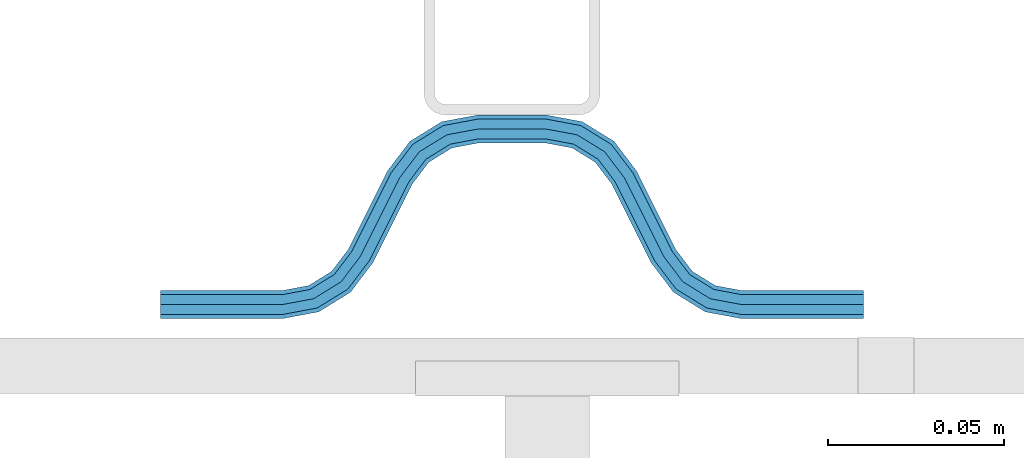
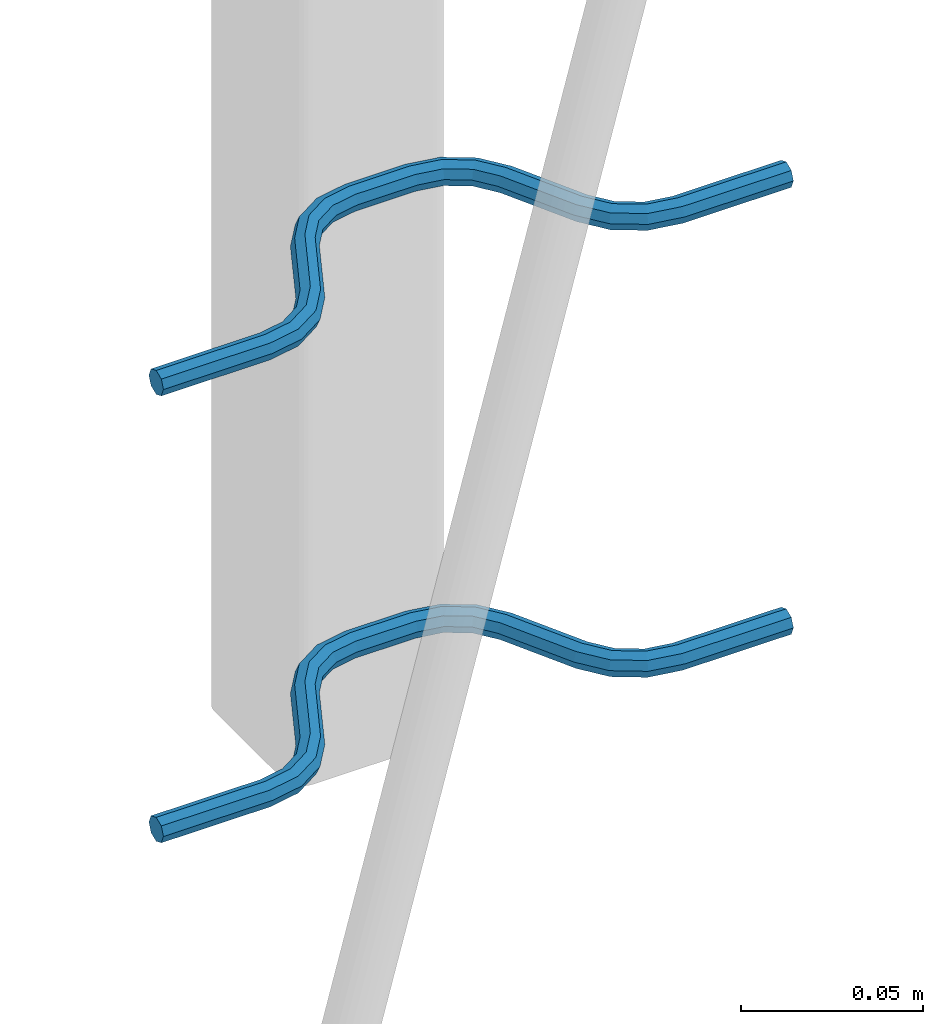
# One storey, part 4 of 5: 2 beams, 2 elements without a shape of their own.
"""IFC2X3 building model written with IfcOpenShell, lengths in millimetres."""

from ifc_helpers import new_model, si_unit, frame, origin_with_axes, place, context, subcontext, project, spatial, faceted_brep, material, type_object, element, aggregate, save


model = new_model("IFC2X3")

# Units and contexts
model_context = context("Model", 3, precision=1e-05, world=origin_with_axes())
body_context = subcontext(model_context, "Body", "Model", "MODEL_VIEW")
ifc_project = project(units=[si_unit("LENGTHUNIT", "METRE", prefix="MILLI"), si_unit("AREAUNIT", "SQUARE_METRE"), si_unit("VOLUMEUNIT", "CUBIC_METRE"), si_unit("MASSUNIT", "GRAM", prefix="KILO"), si_unit("TIMEUNIT", "SECOND"), si_unit("PLANEANGLEUNIT", "RADIAN"), si_unit("SOLIDANGLEUNIT", "STERADIAN"), si_unit("THERMODYNAMICTEMPERATUREUNIT", "DEGREE_CELSIUS"), si_unit("LUMINOUSINTENSITYUNIT", "LUMEN")], contexts=[model_context])

# Site, building, storey
site_placement = place(None, origin_with_axes())
site = spatial("IfcSite", under=ifc_project, at=site_placement, CompositionType="ELEMENT")
building_placement = place(site_placement, origin_with_axes())
building = spatial("IfcBuilding", under=site, at=building_placement, Name="Undefined", CompositionType="ELEMENT")
storey_placement = place(building_placement, origin_with_axes())
storey = spatial("IfcBuildingStorey", under=building, at=storey_placement, Name="Undefined", CompositionType="ELEMENT", Elevation=0.0)

# Assembly, beam
assembly_1_placement = place(storey_placement, origin_with_axes())
assembly_1 = element("IfcElementAssembly", 1, at=assembly_1_placement, inside=storey, Name="Steel Assembly", AssemblyPlace="NOTDEFINED", PredefinedType="NOTDEFINED")
ifc_material = material(Name="REBAR/A500HW")
beam_type = type_object("IfcBeamType", Name="D8", PredefinedType="NOTDEFINED")
beam_1_placement = place(assembly_1_placement, frame((42320.0028955972, 6595.97468822386, 2580.99992151562), z_axis=(0.0, 0.0, 1.0), x_axis=(-0.999999999544916, 3.01690000137701e-05, 0.0)))
beam_1 = element("IfcBeam", 2, at=beam_1_placement, type_object=beam_type, material=ifc_material, Name="AnchorRebar", ObjectType="D8", context=body_context, shape_type="Brep", body=[
    faceted_brep([(3.97994881495833e-09, -4.00000000000091, 0.0), (2.8085196390748e-09, -2.82842712474758, -2.82842712474621), (34.5491497841067, -2.82842709033048, -2.82842712474621), (34.5491497849507, -3.99999996579936, 0.0), (-7.27595761418343e-12, -9.09494701772928e-13, -4.0), (34.5491497812909, 3.44161890097894e-08, -4.0), (-2.82307155430317e-09, 2.82842712474485, -2.82842712474621), (34.5491497784751, 2.82842715916104, -2.82842712474621), (-3.9945007301867e-09, 3.99999999999909, 0.0), (34.5491497773037, 4.00000003441619, 0.0), (-2.82307155430317e-09, 2.82842712474485, 2.82842712474621), (34.5491497784751, 2.82842715916104, 2.82842712474621), (-7.27595761418343e-12, -9.09494701772928e-13, 4.0), (34.5491497812909, 3.44161890097894e-08, 4.0), (2.8085196390748e-09, -2.82842712474758, 2.82842712474621), (34.5491497841067, -2.82842709033048, 2.82842712474621), (45.0102956714691, 2.04744773578568, 0.0), (44.5876751631804, 0.954756147099033, -2.82842712474621), (43.5673790003711, -1.68323470581527, -4.0), (42.5470828375619, -4.3212255587232, -2.82842712474621), (42.1244623293023, -5.41391714741258, 0.0), (42.5470828375619, -4.3212255587232, 2.82842712474621), (43.5673790003711, -1.68323470581527, 4.0), (44.5876751631804, 0.954756147099033, 2.82842712474621), (53.274424971547, -4.41395065588222, 2.82842712474621), (54.0627564272581, -3.5472808699069, 0.0), (51.3712244794879, -6.50627660728151, 4.0), (49.4680239874506, -8.59860255868261, 2.82842712474621), (48.6796925317176, -9.4652723446543, 0.0), (49.4680239874506, -8.59860255868261, -2.82842712474621), (51.3712244794879, -6.50627660728151, -4.0), (53.274424971547, -4.41395065588222, -2.82842712474621), (59.4396520724549, -12.5547497421876, 2.82842712474621), (60.4875387236025, -12.0308064548954, 0.0), (56.9098299073739, -13.8196607322834, 4.0), (54.3800077422784, -15.0845717223683, 2.82842712474621), (53.3321210918803, -15.6085150094559, 0.0), (54.3800077422784, -15.0845717223683, -2.82842712474621), (56.9098299073739, -13.8196607322834, -4.0), (59.4396520724549, -12.5547497421876, -2.82842712474621), (65.5603461982682, -37.4452502676068, -2.82842712474621), (64.5124595463058, -37.9691935549445, 0.0), (68.0901683634002, -36.1803392775319, -4.0), (70.6199905285321, -34.9154282874579, -2.82842712474621), (71.6678771797233, -34.3914850001738, 0.0), (70.6199905285321, -34.9154282874579, 2.82842712474621), (68.0901683634002, -36.1803392775319, 4.0), (65.5603461982682, -37.4452502676068, 2.82842712474621), (76.3203055137128, -40.5347274610476, 0.0), (75.5319740454433, -41.4013972356079, -2.82842712474621), (73.628773523058, -43.4937231594477, -4.0), (71.7255730006873, -45.586049083292, -2.82842712474621), (70.9372415324033, -46.4527188578513, 0.0), (71.7255730006873, -45.586049083292, 2.82842712474621), (73.628773523058, -43.4937231594477, 4.0), (75.5319740454433, -41.4013972356079, 2.82842712474621), (82.4529148344736, -45.6787742201832, 2.82842712474621), (82.8755353743836, -44.5860826437265, 0.0), (81.4326185952377, -48.3167650435544, 4.0), (80.4123223560309, -50.9547558669201, 2.82842712474621), (79.9897018161209, -52.0474474433813, 0.0), (80.4123223560309, -50.9547558669201, -2.82842712474621), (81.4326185952377, -48.3167650435544, -4.0), (82.4529148344736, -45.6787742201832, -2.82842712474621), (90.4508475245966, -47.1715729199359, 2.82842712474621), (90.4508475742841, -46.000000044688, 0.0), (90.4508474046088, -50.0000000446771, 4.0), (90.4508472846428, -52.8284271694056, 2.82842712474621), (90.4508472356392, -54.0000000440459, 0.0), (90.4508472846428, -52.8284271694056, -2.82842712474621), (90.4508474046088, -50.0000000446771, -4.0), (90.4508475245966, -47.1715729199359, -2.82842712474621), (109.549147724516, -52.8284279786703, -2.82842712474621), (109.54914767341, -54.0000008540392, 0.0), (109.54914784446, -50.0000008539246, -4.0), (109.549147964404, -47.171573729177, -2.82842712474621), (109.549148014084, -46.0000008539246, 0.0), (109.549147964404, -47.171573729177, 2.82842712474621), (109.54914784446, -50.0000008539246, 4.0), (109.549147724516, -52.8284279786703, 2.82842712474621), (120.010293570755, -52.0474490194165, 0.0), (119.58767311088, -50.954757411987, 2.82842712474621), (118.567377064988, -48.316766513838, 4.0), (117.547081019067, -45.6787756156891, 2.82842712474621), (117.124460559222, -44.586084008266, 0.0), (117.547081019067, -45.6787756156891, -2.82842712474621), (118.567377064988, -48.316766513838, -4.0), (119.58767311088, -50.954757411987, -2.82842712474621), (128.274423097741, -45.5860510482489, -2.82842712474621), (129.062754512561, -46.4527208714499, 0.0), (126.371222704453, -43.4937250069761, -4.0), (124.468022311172, -41.4013989657033, -2.82842712474621), (123.679690896359, -40.5347291425014, 0.0), (124.468022311172, -41.4013989657033, 2.82842712474621), (126.371222704453, -43.4937250069761, 4.0), (128.274423097741, -45.5860510482489, 2.82842712474621), (134.439650547101, -37.4452523250511, -2.82842712474621), (135.487537173387, -37.9691956638335, 0.0), (131.909828445358, -36.1803412081899, -4.0), (129.380006343621, -34.9154300913378, -2.82842712474621), (128.332119718681, -34.3914867515423, 0.0), (129.380006343621, -34.9154300913378, 2.82842712474621), (131.909828445358, -36.1803412081899, 4.0), (134.439650547101, -37.4452523250511, 2.82842712474621), (145.619991993379, -15.0845705988722, -2.82842712474621), (146.66787861682, -15.6085139395227, 0.0), (143.090169891606, -13.8196594820974, -4.0), (140.560347789826, -12.5547483653227, -2.82842712474621), (139.512461164864, -12.0308050255589, 0.0), (140.560347789826, -12.5547483653227, 2.82842712474621), (143.090169891606, -13.8196594820974, 4.0), (145.619991993379, -15.0845705988722, 2.82842712474621), (151.32030721409, -9.46527175248229, 0.0), (150.531975786696, -8.59860194074281, 2.82842712474621), (148.62877536298, -6.50627592714864, 4.0), (146.725574939279, -4.41394991354628, 2.82842712474621), (145.937243511864, -3.5472801018077, 0.0), (146.725574939279, -4.41394991354628, -2.82842712474621), (148.62877536298, -6.50627592714864, -4.0), (150.531975786696, -8.59860194074281, -2.82842712474621), (157.452916717564, -4.32122530571087, -2.82842712474621), (157.875537209118, -5.41391690087676, 0.0), (156.432620595137, -1.68323443716054, -4.0), (155.412324472702, 0.95475643138434, -2.82842712474621), (154.989703981155, 2.04744802655023, 0.0), (155.412324472702, 0.95475643138434, 2.82842712474621), (156.432620595137, -1.68323443716054, 4.0), (157.452916717564, -4.32122530571087, 2.82842712474621), (165.450849409564, -2.82842696003536, -2.82842712474621), (165.450849412795, -3.99999983546877, 0.0), (165.450849406625, 1.64712218975183e-07, -4.0), (165.450849403685, 2.82842728945616, -2.82842712474621), (165.45084940247, 4.00000016471495, 0.0), (165.450849403685, 2.82842728945616, 2.82842712474621), (165.450849406625, 1.64712218975183e-07, 4.0), (165.450849409564, -2.82842696003536, 2.82842712474621), (200.000000091874, -2.82842692587838, -2.82842712474621), (200.000000093038, -3.99999980113171, 0.0), (200.000000089065, 1.98867383005563e-07, -4.0), (200.000000086249, 2.82842732361496, -2.82842712474621), (200.000000085085, 4.00000019886738, 0.0), (200.000000086249, 2.82842732361496, 2.82842712474621), (200.000000089065, 1.98867383005563e-07, 4.0), (200.000000091874, -2.82842692587838, 2.82842712474621)], [[[0, 1, 2, 3]], [[1, 4, 5, 2]], [[4, 6, 7, 5]], [[6, 8, 9, 7]], [[8, 10, 11, 9]], [[10, 12, 13, 11]], [[12, 14, 15, 13]], [[14, 0, 3, 15]], [[14, 12, 10, 8, 6, 4, 1, 0]], [[7, 9, 16, 17]], [[5, 7, 17, 18]], [[2, 5, 18, 19]], [[3, 2, 19, 20]], [[15, 3, 20, 21]], [[13, 15, 21, 22]], [[11, 13, 22, 23]], [[9, 11, 23, 16]], [[23, 24, 25, 16]], [[22, 26, 24, 23]], [[21, 27, 26, 22]], [[20, 28, 27, 21]], [[19, 29, 28, 20]], [[18, 30, 29, 19]], [[17, 31, 30, 18]], [[16, 25, 31, 17]], [[24, 32, 33, 25]], [[26, 34, 32, 24]], [[27, 35, 34, 26]], [[28, 36, 35, 27]], [[29, 37, 36, 28]], [[30, 38, 37, 29]], [[31, 39, 38, 30]], [[25, 33, 39, 31]], [[36, 37, 40, 41]], [[37, 38, 42, 40]], [[38, 39, 43, 42]], [[39, 33, 44, 43]], [[33, 32, 45, 44]], [[32, 34, 46, 45]], [[34, 35, 47, 46]], [[35, 36, 41, 47]], [[43, 44, 48, 49]], [[42, 43, 49, 50]], [[40, 42, 50, 51]], [[41, 40, 51, 52]], [[47, 41, 52, 53]], [[46, 47, 53, 54]], [[45, 46, 54, 55]], [[44, 45, 55, 48]], [[55, 56, 57, 48]], [[54, 58, 56, 55]], [[53, 59, 58, 54]], [[52, 60, 59, 53]], [[51, 61, 60, 52]], [[50, 62, 61, 51]], [[49, 63, 62, 50]], [[48, 57, 63, 49]], [[56, 64, 65, 57]], [[58, 66, 64, 56]], [[59, 67, 66, 58]], [[60, 68, 67, 59]], [[61, 69, 68, 60]], [[62, 70, 69, 61]], [[63, 71, 70, 62]], [[57, 65, 71, 63]], [[68, 69, 72, 73]], [[69, 70, 74, 72]], [[70, 71, 75, 74]], [[71, 65, 76, 75]], [[65, 64, 77, 76]], [[64, 66, 78, 77]], [[66, 67, 79, 78]], [[67, 68, 73, 79]], [[79, 73, 80, 81]], [[78, 79, 81, 82]], [[77, 78, 82, 83]], [[76, 77, 83, 84]], [[75, 76, 84, 85]], [[74, 75, 85, 86]], [[72, 74, 86, 87]], [[73, 72, 87, 80]], [[87, 88, 89, 80]], [[86, 90, 88, 87]], [[85, 91, 90, 86]], [[84, 92, 91, 85]], [[83, 93, 92, 84]], [[82, 94, 93, 83]], [[81, 95, 94, 82]], [[80, 89, 95, 81]], [[88, 96, 97, 89]], [[90, 98, 96, 88]], [[91, 99, 98, 90]], [[92, 100, 99, 91]], [[93, 101, 100, 92]], [[94, 102, 101, 93]], [[95, 103, 102, 94]], [[89, 97, 103, 95]], [[97, 96, 104, 105]], [[96, 98, 106, 104]], [[98, 99, 107, 106]], [[99, 100, 108, 107]], [[100, 101, 109, 108]], [[101, 102, 110, 109]], [[102, 103, 111, 110]], [[103, 97, 105, 111]], [[111, 105, 112, 113]], [[110, 111, 113, 114]], [[109, 110, 114, 115]], [[108, 109, 115, 116]], [[107, 108, 116, 117]], [[106, 107, 117, 118]], [[104, 106, 118, 119]], [[105, 104, 119, 112]], [[119, 120, 121, 112]], [[118, 122, 120, 119]], [[117, 123, 122, 118]], [[116, 124, 123, 117]], [[115, 125, 124, 116]], [[114, 126, 125, 115]], [[113, 127, 126, 114]], [[112, 121, 127, 113]], [[120, 128, 129, 121]], [[122, 130, 128, 120]], [[123, 131, 130, 122]], [[124, 132, 131, 123]], [[125, 133, 132, 124]], [[126, 134, 133, 125]], [[127, 135, 134, 126]], [[121, 129, 135, 127]], [[129, 128, 136, 137]], [[128, 130, 138, 136]], [[130, 131, 139, 138]], [[131, 132, 140, 139]], [[132, 133, 141, 140]], [[133, 134, 142, 141]], [[134, 135, 143, 142]], [[135, 129, 137, 143]], [[138, 139, 140, 141, 142, 143, 137, 136]]]),
])
aggregate(assembly_1, [beam_1])

assembly_2_placement = place(storey_placement, origin_with_axes())
assembly_2 = element("IfcElementAssembly", 3, at=assembly_2_placement, inside=storey, Name="Steel Assembly", AssemblyPlace="NOTDEFINED", PredefinedType="NOTDEFINED")
beam_2_placement = place(assembly_2_placement, frame((42320.0028955972, 6595.97468822386, 2430.99992151562), z_axis=(0.0, 0.0, 1.0), x_axis=(-0.999999999544916, 3.01690000137701e-05, 0.0)))
beam_2 = element("IfcBeam", 4, at=beam_2_placement, type_object=beam_type, material=ifc_material, Name="AnchorRebar", ObjectType="D8", context=body_context, shape_type="Brep", body=[
    faceted_brep([(3.97994881495833e-09, -4.00000000000091, 0.0), (2.8085196390748e-09, -2.82842712474758, -2.82842712474621), (34.5491497841067, -2.82842709033048, -2.82842712474621), (34.5491497849507, -3.99999996579936, 0.0), (-7.27595761418343e-12, -9.09494701772928e-13, -4.0), (34.5491497812909, 3.44161890097894e-08, -4.0), (-2.82307155430317e-09, 2.82842712474485, -2.82842712474621), (34.5491497784751, 2.82842715916104, -2.82842712474621), (-3.9945007301867e-09, 3.99999999999909, 0.0), (34.5491497773037, 4.00000003441619, 0.0), (-2.82307155430317e-09, 2.82842712474485, 2.82842712474621), (34.5491497784751, 2.82842715916104, 2.82842712474621), (-7.27595761418343e-12, -9.09494701772928e-13, 4.0), (34.5491497812909, 3.44161890097894e-08, 4.0), (2.8085196390748e-09, -2.82842712474758, 2.82842712474621), (34.5491497841067, -2.82842709033048, 2.82842712474621), (45.0102956714691, 2.04744773578568, 0.0), (44.5876751631804, 0.954756147099033, -2.82842712474621), (43.5673790003711, -1.68323470581527, -4.0), (42.5470828375619, -4.3212255587232, -2.82842712474621), (42.1244623293023, -5.41391714741258, 0.0), (42.5470828375619, -4.3212255587232, 2.82842712474621), (43.5673790003711, -1.68323470581527, 4.0), (44.5876751631804, 0.954756147099033, 2.82842712474621), (53.274424971547, -4.41395065588222, 2.82842712474621), (54.0627564272581, -3.5472808699069, 0.0), (51.3712244794879, -6.50627660728151, 4.0), (49.4680239874506, -8.59860255868261, 2.82842712474621), (48.6796925317176, -9.4652723446543, 0.0), (49.4680239874506, -8.59860255868261, -2.82842712474621), (51.3712244794879, -6.50627660728151, -4.0), (53.274424971547, -4.41395065588222, -2.82842712474621), (59.4396520724549, -12.5547497421876, 2.82842712474621), (60.4875387236025, -12.0308064548954, 0.0), (56.9098299073739, -13.8196607322834, 4.0), (54.3800077422784, -15.0845717223683, 2.82842712474621), (53.3321210918803, -15.6085150094559, 0.0), (54.3800077422784, -15.0845717223683, -2.82842712474621), (56.9098299073739, -13.8196607322834, -4.0), (59.4396520724549, -12.5547497421876, -2.82842712474621), (65.5603461982682, -37.4452502676068, -2.82842712474621), (64.5124595463058, -37.9691935549445, 0.0), (68.0901683634002, -36.1803392775319, -4.0), (70.6199905285321, -34.9154282874579, -2.82842712474621), (71.6678771797233, -34.3914850001738, 0.0), (70.6199905285321, -34.9154282874579, 2.82842712474621), (68.0901683634002, -36.1803392775319, 4.0), (65.5603461982682, -37.4452502676068, 2.82842712474621), (76.3203055137128, -40.5347274610476, 0.0), (75.5319740454433, -41.4013972356079, -2.82842712474621), (73.628773523058, -43.4937231594477, -4.0), (71.7255730006873, -45.586049083292, -2.82842712474621), (70.9372415324033, -46.4527188578513, 0.0), (71.7255730006873, -45.586049083292, 2.82842712474621), (73.628773523058, -43.4937231594477, 4.0), (75.5319740454433, -41.4013972356079, 2.82842712474621), (82.4529148344736, -45.6787742201832, 2.82842712474621), (82.8755353743836, -44.5860826437265, 0.0), (81.4326185952377, -48.3167650435544, 4.0), (80.4123223560309, -50.9547558669201, 2.82842712474621), (79.9897018161209, -52.0474474433813, 0.0), (80.4123223560309, -50.9547558669201, -2.82842712474621), (81.4326185952377, -48.3167650435544, -4.0), (82.4529148344736, -45.6787742201832, -2.82842712474621), (90.4508475245966, -47.1715729199359, 2.82842712474621), (90.4508475742841, -46.000000044688, 0.0), (90.4508474046088, -50.0000000446771, 4.0), (90.4508472846428, -52.8284271694056, 2.82842712474621), (90.4508472356392, -54.0000000440459, 0.0), (90.4508472846428, -52.8284271694056, -2.82842712474621), (90.4508474046088, -50.0000000446771, -4.0), (90.4508475245966, -47.1715729199359, -2.82842712474621), (109.549147724516, -52.8284279786703, -2.82842712474621), (109.54914767341, -54.0000008540392, 0.0), (109.54914784446, -50.0000008539246, -4.0), (109.549147964404, -47.171573729177, -2.82842712474621), (109.549148014084, -46.0000008539246, 0.0), (109.549147964404, -47.171573729177, 2.82842712474621), (109.54914784446, -50.0000008539246, 4.0), (109.549147724516, -52.8284279786703, 2.82842712474621), (120.010293570755, -52.0474490194165, 0.0), (119.58767311088, -50.954757411987, 2.82842712474621), (118.567377064988, -48.316766513838, 4.0), (117.547081019067, -45.6787756156891, 2.82842712474621), (117.124460559222, -44.586084008266, 0.0), (117.547081019067, -45.6787756156891, -2.82842712474621), (118.567377064988, -48.316766513838, -4.0), (119.58767311088, -50.954757411987, -2.82842712474621), (128.274423097741, -45.5860510482489, -2.82842712474621), (129.062754512561, -46.4527208714499, 0.0), (126.371222704453, -43.4937250069761, -4.0), (124.468022311172, -41.4013989657033, -2.82842712474621), (123.679690896359, -40.5347291425014, 0.0), (124.468022311172, -41.4013989657033, 2.82842712474621), (126.371222704453, -43.4937250069761, 4.0), (128.274423097741, -45.5860510482489, 2.82842712474621), (134.439650547101, -37.4452523250511, -2.82842712474621), (135.487537173387, -37.9691956638335, 0.0), (131.909828445358, -36.1803412081899, -4.0), (129.380006343621, -34.9154300913378, -2.82842712474621), (128.332119718681, -34.3914867515423, 0.0), (129.380006343621, -34.9154300913378, 2.82842712474621), (131.909828445358, -36.1803412081899, 4.0), (134.439650547101, -37.4452523250511, 2.82842712474621), (145.619991993379, -15.0845705988722, -2.82842712474621), (146.66787861682, -15.6085139395227, 0.0), (143.090169891606, -13.8196594820974, -4.0), (140.560347789826, -12.5547483653227, -2.82842712474621), (139.512461164864, -12.0308050255589, 0.0), (140.560347789826, -12.5547483653227, 2.82842712474621), (143.090169891606, -13.8196594820974, 4.0), (145.619991993379, -15.0845705988722, 2.82842712474621), (151.32030721409, -9.46527175248229, 0.0), (150.531975786696, -8.59860194074281, 2.82842712474621), (148.62877536298, -6.50627592714864, 4.0), (146.725574939279, -4.41394991354628, 2.82842712474621), (145.937243511864, -3.5472801018077, 0.0), (146.725574939279, -4.41394991354628, -2.82842712474621), (148.62877536298, -6.50627592714864, -4.0), (150.531975786696, -8.59860194074281, -2.82842712474621), (157.452916717564, -4.32122530571087, -2.82842712474621), (157.875537209118, -5.41391690087676, 0.0), (156.432620595137, -1.68323443716054, -4.0), (155.412324472702, 0.95475643138434, -2.82842712474621), (154.989703981155, 2.04744802655023, 0.0), (155.412324472702, 0.95475643138434, 2.82842712474621), (156.432620595137, -1.68323443716054, 4.0), (157.452916717564, -4.32122530571087, 2.82842712474621), (165.450849409564, -2.82842696003536, -2.82842712474621), (165.450849412795, -3.99999983546877, 0.0), (165.450849406625, 1.64712218975183e-07, -4.0), (165.450849403685, 2.82842728945616, -2.82842712474621), (165.45084940247, 4.00000016471495, 0.0), (165.450849403685, 2.82842728945616, 2.82842712474621), (165.450849406625, 1.64712218975183e-07, 4.0), (165.450849409564, -2.82842696003536, 2.82842712474621), (200.000000091874, -2.82842692587838, -2.82842712474621), (200.000000093038, -3.99999980113171, 0.0), (200.000000089065, 1.98867383005563e-07, -4.0), (200.000000086249, 2.82842732361496, -2.82842712474621), (200.000000085085, 4.00000019886738, 0.0), (200.000000086249, 2.82842732361496, 2.82842712474621), (200.000000089065, 1.98867383005563e-07, 4.0), (200.000000091874, -2.82842692587838, 2.82842712474621)], [[[0, 1, 2, 3]], [[1, 4, 5, 2]], [[4, 6, 7, 5]], [[6, 8, 9, 7]], [[8, 10, 11, 9]], [[10, 12, 13, 11]], [[12, 14, 15, 13]], [[14, 0, 3, 15]], [[14, 12, 10, 8, 6, 4, 1, 0]], [[7, 9, 16, 17]], [[5, 7, 17, 18]], [[2, 5, 18, 19]], [[3, 2, 19, 20]], [[15, 3, 20, 21]], [[13, 15, 21, 22]], [[11, 13, 22, 23]], [[9, 11, 23, 16]], [[23, 24, 25, 16]], [[22, 26, 24, 23]], [[21, 27, 26, 22]], [[20, 28, 27, 21]], [[19, 29, 28, 20]], [[18, 30, 29, 19]], [[17, 31, 30, 18]], [[16, 25, 31, 17]], [[24, 32, 33, 25]], [[26, 34, 32, 24]], [[27, 35, 34, 26]], [[28, 36, 35, 27]], [[29, 37, 36, 28]], [[30, 38, 37, 29]], [[31, 39, 38, 30]], [[25, 33, 39, 31]], [[36, 37, 40, 41]], [[37, 38, 42, 40]], [[38, 39, 43, 42]], [[39, 33, 44, 43]], [[33, 32, 45, 44]], [[32, 34, 46, 45]], [[34, 35, 47, 46]], [[35, 36, 41, 47]], [[43, 44, 48, 49]], [[42, 43, 49, 50]], [[40, 42, 50, 51]], [[41, 40, 51, 52]], [[47, 41, 52, 53]], [[46, 47, 53, 54]], [[45, 46, 54, 55]], [[44, 45, 55, 48]], [[55, 56, 57, 48]], [[54, 58, 56, 55]], [[53, 59, 58, 54]], [[52, 60, 59, 53]], [[51, 61, 60, 52]], [[50, 62, 61, 51]], [[49, 63, 62, 50]], [[48, 57, 63, 49]], [[56, 64, 65, 57]], [[58, 66, 64, 56]], [[59, 67, 66, 58]], [[60, 68, 67, 59]], [[61, 69, 68, 60]], [[62, 70, 69, 61]], [[63, 71, 70, 62]], [[57, 65, 71, 63]], [[68, 69, 72, 73]], [[69, 70, 74, 72]], [[70, 71, 75, 74]], [[71, 65, 76, 75]], [[65, 64, 77, 76]], [[64, 66, 78, 77]], [[66, 67, 79, 78]], [[67, 68, 73, 79]], [[79, 73, 80, 81]], [[78, 79, 81, 82]], [[77, 78, 82, 83]], [[76, 77, 83, 84]], [[75, 76, 84, 85]], [[74, 75, 85, 86]], [[72, 74, 86, 87]], [[73, 72, 87, 80]], [[87, 88, 89, 80]], [[86, 90, 88, 87]], [[85, 91, 90, 86]], [[84, 92, 91, 85]], [[83, 93, 92, 84]], [[82, 94, 93, 83]], [[81, 95, 94, 82]], [[80, 89, 95, 81]], [[88, 96, 97, 89]], [[90, 98, 96, 88]], [[91, 99, 98, 90]], [[92, 100, 99, 91]], [[93, 101, 100, 92]], [[94, 102, 101, 93]], [[95, 103, 102, 94]], [[89, 97, 103, 95]], [[97, 96, 104, 105]], [[96, 98, 106, 104]], [[98, 99, 107, 106]], [[99, 100, 108, 107]], [[100, 101, 109, 108]], [[101, 102, 110, 109]], [[102, 103, 111, 110]], [[103, 97, 105, 111]], [[111, 105, 112, 113]], [[110, 111, 113, 114]], [[109, 110, 114, 115]], [[108, 109, 115, 116]], [[107, 108, 116, 117]], [[106, 107, 117, 118]], [[104, 106, 118, 119]], [[105, 104, 119, 112]], [[119, 120, 121, 112]], [[118, 122, 120, 119]], [[117, 123, 122, 118]], [[116, 124, 123, 117]], [[115, 125, 124, 116]], [[114, 126, 125, 115]], [[113, 127, 126, 114]], [[112, 121, 127, 113]], [[120, 128, 129, 121]], [[122, 130, 128, 120]], [[123, 131, 130, 122]], [[124, 132, 131, 123]], [[125, 133, 132, 124]], [[126, 134, 133, 125]], [[127, 135, 134, 126]], [[121, 129, 135, 127]], [[129, 128, 136, 137]], [[128, 130, 138, 136]], [[130, 131, 139, 138]], [[131, 132, 140, 139]], [[132, 133, 141, 140]], [[133, 134, 142, 141]], [[134, 135, 143, 142]], [[135, 129, 137, 143]], [[138, 139, 140, 141, 142, 143, 137, 136]]]),
])
aggregate(assembly_2, [beam_2])

save(model, "model.ifc")
